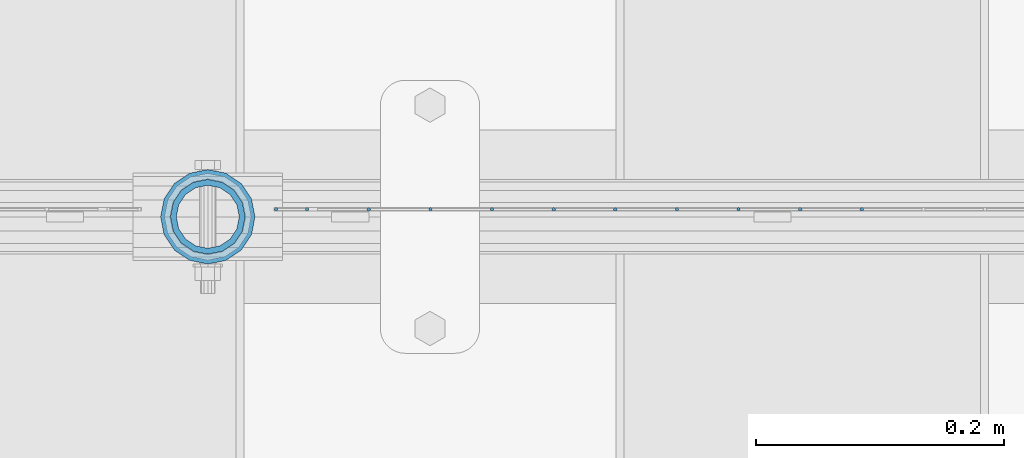
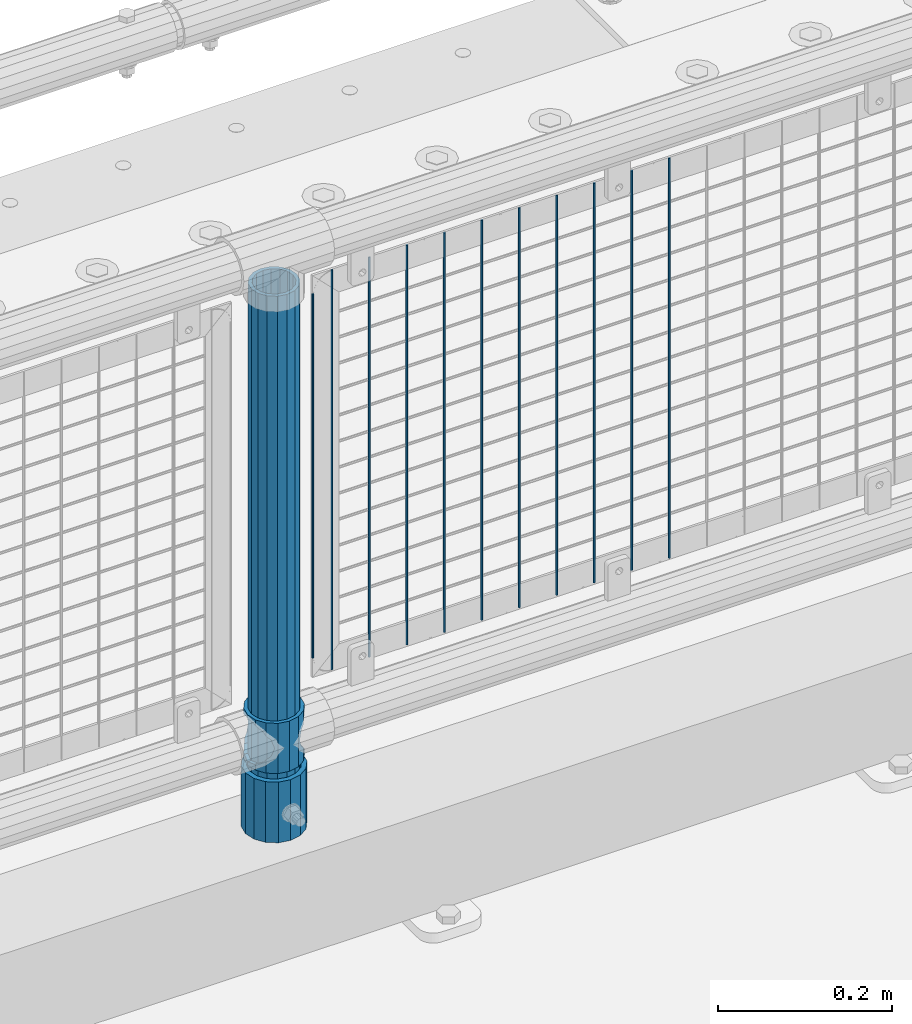
# One storey, part 92 of 257: 14 columns.
"""IFC2X3 building model written with IfcOpenShell, lengths in millimetres."""

import ifcopenshell
import ifcopenshell.guid

model = None  # the IFC model being written
_history = None  # IfcOwnerHistory: only IFC2X3 demands one
_inside = {}  # id of a spatial element -> (the spatial element, [elements in it])
_under = {}  # id of a project, library or spatial element -> (it, [spatial elements below it])
_declared = {}  # id of a project -> (the project, [libraries it declares])
_typed = {}  # id of a type object -> (the type object, [elements of that type])
_made_of = {}  # id of a material, layer set ... -> (it, [elements and type objects made of it])


def new_model(schema):
    """Start an empty IFC model of exactly this schema.

    Asked for "IFC4X3", IfcOpenShell would pick the latest addendum, in which some entities
    have other attributes; the version numbers below select the first issue.
    IFC2X3 requires an IfcOwnerHistory on every rooted entity: one is made here for all.
    """
    global model, _history
    if schema == "IFC4X3":
        model = ifcopenshell.file(schema_version=(4, 3, 0, 0))
    else:
        model = ifcopenshell.file(schema=schema)
    _inside.clear()
    _under.clear()
    _declared.clear()
    _typed.clear()
    _made_of.clear()
    _history = None
    if model.schema == "IFC2X3":
        org = make("IfcOrganization", Name="unknown")
        user = make(
            "IfcPersonAndOrganization",
            ThePerson=make("IfcPerson", FamilyName="unknown"),
            TheOrganization=org,
        )
        app = make(
            "IfcApplication",
            ApplicationDeveloper=org,
            Version="unknown",
            ApplicationFullName="unknown",
            ApplicationIdentifier="unknown",
        )
        _history = make(
            "IfcOwnerHistory",
            OwningUser=user,
            OwningApplication=app,
            ChangeAction="ADDED",
            CreationDate=0,
        )
    return model


def make(cls, **values):
    """One entity of the class cls with the attributes given. An attribute that is None is left unset."""
    return model.create_entity(
        cls, **{name: value for name, value in values.items() if value is not None}
    )


def rooted(cls, **values):
    """An entity with a GlobalId (a new one), such as an element, a storey or a relation."""
    return make(cls, GlobalId=ifcopenshell.guid.new(), OwnerHistory=_history, **values)


def si_unit(unit_type, name, prefix=None):
    """IfcSIUnit, for example si_unit("LENGTHUNIT", "METRE", prefix="MILLI")."""
    return make("IfcSIUnit", UnitType=unit_type, Prefix=prefix, Name=name)


def assignment(units):
    """IfcUnitAssignment: the units of a project."""
    return None if units is None else make("IfcUnitAssignment", Units=units)


def point(xyz):
    """IfcCartesianPoint."""
    return None if xyz is None else make("IfcCartesianPoint", Coordinates=xyz)


def direction(xyz):
    """IfcDirection."""
    return None if xyz is None else make("IfcDirection", DirectionRatios=xyz)


def frame(location, z_axis=None, x_axis=None):
    """IfcAxis2Placement3D, a coordinate frame: its origin and axes. An axis left out is left unset."""
    return make(
        "IfcAxis2Placement3D",
        Location=point(location),
        Axis=direction(z_axis),
        RefDirection=direction(x_axis),
    )


def origin_with_axes():
    """The frame at (0, 0, 0) with the z axis (0, 0, 1) and the x axis (1, 0, 0) written out."""
    return frame((0.0, 0.0, 0.0), z_axis=(0.0, 0.0, 1.0), x_axis=(1.0, 0.0, 0.0))


def place(relative_to, where):
    """IfcLocalPlacement: puts the frame where relative to a parent placement (None: the world)."""
    return make(
        "IfcLocalPlacement", PlacementRelTo=relative_to, RelativePlacement=where
    )


def context(
    kind, dimensions, precision=None, world=None, true_north=None, identifier=None
):
    """IfcGeometricRepresentationContext, for example the 3D "Model" context."""
    return make(
        "IfcGeometricRepresentationContext",
        ContextIdentifier=identifier,
        ContextType=kind,
        CoordinateSpaceDimension=dimensions,
        Precision=precision,
        WorldCoordinateSystem=world,
        TrueNorth=true_north,
    )


def subcontext(parent, identifier, kind, view, scale=None):
    """IfcGeometricRepresentationSubContext, for example "Body" below "Model"."""
    return make(
        "IfcGeometricRepresentationSubContext",
        ContextIdentifier=identifier,
        ContextType=kind,
        ParentContext=parent,
        TargetScale=scale,
        TargetView=view,
    )


def project(units=None, contexts=None):
    """IfcProject with its units and contexts."""
    return rooted(
        "IfcProject",
        Name="project",
        RepresentationContexts=contexts,
        UnitsInContext=assignment(units),
    )


def spatial(cls, under=None, at=None, **own):
    """A site, building, storey or space (cls), placed at a placement, below another one or the project."""
    s = rooted(cls, ObjectPlacement=at, **own)
    if under is not None:
        _under.setdefault(under.id(), (under, []))[1].append(s)
    return s


def faces_of(points, faces, orient=None, outer=None):
    """IfcFace entities. A face is a list of loops; a loop is a list of indices into points, from 0.

    orient and outer hold one flag for each loop. By default every Orientation is true, the
    first loop of a face is its IfcFaceOuterBound and the others are IfcFaceBound.
    """
    made = []
    for i, loops in enumerate(faces):
        bounds = []
        for j, loop in enumerate(loops):
            is_outer = j == 0 if outer is None else outer[i][j]
            bounds.append(
                make(
                    "IfcFaceOuterBound" if is_outer else "IfcFaceBound",
                    Bound=make("IfcPolyLoop", Polygon=[points[k] for k in loop]),
                    Orientation=True if orient is None else orient[i][j],
                )
            )
        made.append(make("IfcFace", Bounds=bounds))
    return made


def faceted_brep(points, faces, orient=None, outer=None, voids=None):
    """IfcFacetedBrep: a solid bounded by flat faces; with voids (closed shells), ...WithVoids."""
    shared = [point(p) for p in points]
    hull = make("IfcClosedShell", CfsFaces=faces_of(shared, faces, orient, outer))
    if voids is None:
        return make("IfcFacetedBrep", Outer=hull)
    return make(
        "IfcFacetedBrepWithVoids",
        Outer=hull,
        Voids=[
            make(cls, CfsFaces=faces_of(shared, fs, o, b)) for cls, fs, o, b in voids
        ],
    )


def shape(context_of_items, identifier, shape_type, items):
    """IfcShapeRepresentation: the items that make up one representation, for example the "Body"."""
    return make(
        "IfcShapeRepresentation",
        ContextOfItems=context_of_items,
        RepresentationIdentifier=identifier,
        RepresentationType=shape_type,
        Items=items,
    )


def material(Name=None, Category=None):
    """IfcMaterial."""
    return make("IfcMaterial", Name=Name, Category=Category)


def made_of(thing, what):
    """Note that an element or type object is made of a material, layer set ...; save() writes the relation."""
    if what is not None:
        _made_of.setdefault(what.id(), (what, []))[1].append(thing)
    return thing


def type_object(cls, material=None, **own):
    """A type object (cls), such as IfcWallType, which elements share."""
    return made_of(rooted(cls, **own), material)


def element(
    cls,
    number,
    at=None,
    inside=None,
    cuts=None,
    type_object=None,
    material=None,
    context=None,
    identifier="Body",
    shape_type=None,
    held_by="IfcProductDefinitionShape",
    body=None,
    shapes=None,
    **own,
):
    """One element of the class cls, such as IfcWall. Its Tag is "e" and its number.

    at: its placement. inside: the storey or other place that contains it. cuts: it is an
    opening in that element (IfcRelVoidsElement). A single representation is given by context,
    identifier, shape_type and body (its items); several are given by shapes. held_by: the class
    of the entity that holds the representations. save() writes the other relations.
    """
    e = rooted(cls, Tag="e%d" % number, ObjectPlacement=at, **own)
    if body is not None:
        shapes = [shape(context, identifier, shape_type, body)]
    if shapes is not None:
        e.Representation = make(held_by, Representations=shapes)
    if inside is not None:
        _inside.setdefault(inside.id(), (inside, []))[1].append(e)
    if cuts is not None:
        rooted(
            "IfcRelVoidsElement", RelatingBuildingElement=cuts, RelatedOpeningElement=e
        )
    if type_object is not None:
        _typed.setdefault(type_object.id(), (type_object, []))[1].append(e)
    return made_of(e, material)


def aggregate(whole, parts):
    """IfcRelAggregates: a whole, such as a stair, and the parts it consists of."""
    return rooted("IfcRelAggregates", RelatingObject=whole, RelatedObjects=parts)


def save(model, path):
    """Write the relations noted so far, then the file.

    IfcRelAggregates (storeys below a building ...), IfcRelContainedInSpatialStructure (elements
    in a storey), IfcRelDefinesByType, IfcRelAssociatesMaterial and IfcRelDeclares: one each for
    every whole, place, type object, material and project.
    """
    for whole, parts in _under.values():
        aggregate(whole, parts)
    for where, things in _inside.values():
        rooted(
            "IfcRelContainedInSpatialStructure",
            RelatedElements=things,
            RelatingStructure=where,
        )
    for kind, things in _typed.values():
        rooted("IfcRelDefinesByType", RelatedObjects=things, RelatingType=kind)
    for what, things in _made_of.values():
        rooted("IfcRelAssociatesMaterial", RelatedObjects=things, RelatingMaterial=what)
    for by, libraries in _declared.values():
        rooted("IfcRelDeclares", RelatingContext=by, RelatedDefinitions=libraries)
    model.write(path)


model = new_model("IFC2X3")

# Units and contexts
model_context = context("Model", 3, precision=1e-05, world=origin_with_axes())
body_context = subcontext(model_context, "Body", "Model", "MODEL_VIEW")
ifc_project = project(units=[si_unit("LENGTHUNIT", "METRE", prefix="MILLI"), si_unit("AREAUNIT", "SQUARE_METRE"), si_unit("VOLUMEUNIT", "CUBIC_METRE"), si_unit("MASSUNIT", "GRAM", prefix="KILO"), si_unit("TIMEUNIT", "SECOND"), si_unit("PLANEANGLEUNIT", "RADIAN"), si_unit("SOLIDANGLEUNIT", "STERADIAN"), si_unit("THERMODYNAMICTEMPERATUREUNIT", "DEGREE_CELSIUS"), si_unit("LUMINOUSINTENSITYUNIT", "LUMEN")], contexts=[model_context])

# Site, building, storey
site_placement = place(None, origin_with_axes())
site = spatial("IfcSite", under=ifc_project, at=site_placement, CompositionType="ELEMENT")
building_placement = place(site_placement, origin_with_axes())
building = spatial("IfcBuilding", under=site, at=building_placement, Name="Standard", CompositionType="ELEMENT")
storey_placement = place(building_placement, origin_with_axes())
storey = spatial("IfcBuildingStorey", under=building, at=storey_placement, Name="Undefined", CompositionType="ELEMENT", Elevation=0.0)

# Columns
ifc_material_1 = material()
column_type_1 = type_object("IfcColumnType", PredefinedType="NOTDEFINED")
column_1_placement = place(storey_placement, frame((55870.9999998042, 10664.5, 168.019999999998), z_axis=(0.0, 1.0, 0.0), x_axis=(0.0, 0.0, 1.0)))
element("IfcColumn", 1, at=column_1_placement, inside=storey, type_object=column_type_1, material=ifc_material_1, context=body_context, shape_type="Brep", body=[
    faceted_brep([(0.0, -31.75, 0.0), (0.0, -29.3331751572332, 12.1501989775916), (85.0, -29.3331751572332, 12.1501989775916), (85.0, -31.75, 0.0), (0.0, -22.4506403026753, 22.4506403026735), (85.0, -22.4506403026753, 22.4506403026735), (0.0, -12.1501989775934, 29.3331751572332), (85.0, -12.1501989775934, 29.3331751572332), (0.0, 0.0, 31.75), (85.0, 0.0, 31.75), (0.0, 12.1501989775934, 29.3331751572332), (85.0, 12.1501989775934, 29.3331751572332), (0.0, 22.4506403026753, 22.4506403026735), (85.0, 22.4506403026753, 22.4506403026735), (0.0, 29.3331751572332, 12.1501989775916), (85.0, 29.3331751572332, 12.1501989775916), (0.0, 31.75, 0.0), (85.0, 31.75, 0.0), (0.0, 29.3331751572332, -12.1501989775916), (85.0, 29.3331751572332, -12.1501989775916), (0.0, 22.4506403026753, -22.4506403026735), (85.0, 22.4506403026753, -22.4506403026735), (0.0, 12.1501989775934, -29.3331751572332), (85.0, 12.1501989775934, -29.3331751572332), (0.0, 0.0, -31.75), (85.0, 0.0, -31.75), (0.0, -12.1501989775934, -29.3331751572332), (85.0, -12.1501989775934, -29.3331751572332), (0.0, -22.4506403026753, -22.4506403026735), (85.0, -22.4506403026753, -22.4506403026735), (0.0, -29.3331751572332, -12.1501989775916), (85.0, -29.3331751572332, -12.1501989775916), (0.0, -38.0500000000029, 0.0), (0.0, -35.1536162120537, -14.561104601491), (85.0, -35.1536162120537, -14.561104601491), (85.0, -38.0500000000029, 0.0), (0.0, -26.9054130241493, -26.9054130241475), (85.0, -26.9054130241493, -26.9054130241475), (0.0, -14.5611046014892, -35.1536162120537), (85.0, -14.5611046014892, -35.1536162120537), (0.0, 0.0, -38.0499999999993), (85.0, 0.0, -38.0499999999993), (0.0, 14.5611046014892, -35.1536162120537), (85.0, 14.5611046014892, -35.1536162120537), (0.0, 26.9054130241493, -26.9054130241475), (85.0, 26.9054130241493, -26.9054130241475), (0.0, 35.1536162120537, -14.561104601491), (85.0, 35.1536162120537, -14.561104601491), (0.0, 38.0500000000029, 0.0), (85.0, 38.0500000000029, 0.0), (0.0, 35.1536162120537, 14.561104601491), (85.0, 35.1536162120537, 14.561104601491), (0.0, 26.9054130241493, 26.9054130241475), (85.0, 26.9054130241493, 26.9054130241475), (0.0, 14.5611046014892, 35.1536162120537), (85.0, 14.5611046014892, 35.1536162120537), (0.0, 0.0, 38.0499999999993), (85.0, 0.0, 38.0499999999993), (0.0, -14.5611046014892, 35.1536162120537), (85.0, -14.5611046014892, 35.1536162120537), (0.0, -26.9054130241493, 26.9054130241475), (85.0, -26.9054130241493, 26.9054130241475), (0.0, -35.1536162120537, 14.561104601491), (85.0, -35.1536162120537, 14.561104601491)], [[[0, 1, 2, 3]], [[1, 4, 5, 2]], [[4, 6, 7, 5]], [[6, 8, 9, 7]], [[8, 10, 11, 9]], [[10, 12, 13, 11]], [[12, 14, 15, 13]], [[14, 16, 17, 15]], [[16, 18, 19, 17]], [[18, 20, 21, 19]], [[20, 22, 23, 21]], [[22, 24, 25, 23]], [[24, 26, 27, 25]], [[26, 28, 29, 27]], [[28, 30, 31, 29]], [[30, 0, 3, 31]], [[32, 33, 34, 35]], [[33, 36, 37, 34]], [[36, 38, 39, 37]], [[38, 40, 41, 39]], [[40, 42, 43, 41]], [[42, 44, 45, 43]], [[44, 46, 47, 45]], [[46, 48, 49, 47]], [[48, 50, 51, 49]], [[50, 52, 53, 51]], [[52, 54, 55, 53]], [[54, 56, 57, 55]], [[56, 58, 59, 57]], [[58, 60, 61, 59]], [[60, 62, 63, 61]], [[62, 32, 35, 63]], [[37, 39, 41, 43, 45, 47, 49, 51, 53, 55, 57, 59, 61, 63, 35, 34], [5, 7, 9, 11, 13, 15, 17, 19, 21, 23, 25, 27, 29, 31, 3, 2]], [[62, 60, 58, 56, 54, 52, 50, 48, 46, 44, 42, 40, 38, 36, 33, 32], [30, 28, 26, 24, 22, 20, 18, 16, 14, 12, 10, 8, 6, 4, 1, 0]]]),
])
ifc_material_2 = material(Name="Misc_Undefined")
column_type_2 = type_object("IfcColumnType", PredefinedType="NOTDEFINED")
column_2_placement = place(storey_placement, frame((55871.0, 10664.5, 263.02), z_axis=(-1.0, 0.0, 0.0), x_axis=(0.0, 0.0, 1.0)))
element("IfcColumn", 2, at=column_2_placement, inside=storey, type_object=column_type_2, material=ifc_material_2, context=body_context, shape_type="Brep", body=[
    faceted_brep([(63.1897438117172, 11.6144421722802, -32.8397438117245), (63.1897438117172, 11.6144421722802, -28.0397438117143), (56.6106908090114, 21.4606908090118, -21.4606908090136), (56.6106908090114, 21.4606908090118, -27.1226768591077), (61.9623795176756, 13.4513226476338, -32.4743655677739), (46.7644421722801, 28.0397438117179, -11.6144421722784), (46.7644421722801, 28.0397438117179, -20.0882031229921), (51.5310424080039, 24.8548033587067, -24.8548033587067), (35.1500000000015, 30.35, 0.0), (35.1499999999996, 30.3500000000004, -16.6306603983758), (23.5355578277192, 28.0397438117179, -11.6144421722784), (23.5355578277192, 28.0397438117179, -20.0882031229921), (18.7689575919954, 24.8548033587067, -24.8548033587067), (13.6893091909879, 21.4606908090118, -21.4606908090136), (13.6893091909879, 21.4606908090118, -27.1226768591077), (8.3376204823237, 13.4513226476338, -32.4743655677739), (7.11025618828211, 11.6144421722802, -28.0397438117143), (7.11025618828211, 11.6144421722802, -32.8397438117245), (4.79999999999961, 0.0, -30.3499999999985), (4.79999999999961, 0.0, -35.1500000000015), (7.11025618828205, -11.6144421722802, -28.0397438117143), (7.11025618828205, -11.6144421722802, -32.8397438117245), (13.6893091909879, -21.4606908090118, -21.4606908090136), (13.6893091909879, -21.4606908090118, -27.1226768591077), (8.33762048232484, -13.4513226476338, -32.4743655677739), (23.5355578277191, -28.0397438117179, -11.6144421722784), (23.5355578277191, -28.0397438117179, -20.0882031229849), (18.7689575919987, -24.8548033587067, -24.8548033587067), (35.1500000000015, -30.35, 0.0), (35.1499999999996, -30.3500000000004, -16.6306603983685), (46.7644421722801, -28.0397438117179, -11.6144421722784), (46.7644421722801, -28.0397438117179, -20.0882031229849), (51.5310424080038, -24.8548033587067, -24.8548033587067), (56.6106908090114, -21.4606908090118, -21.4606908090136), (56.6106908090114, -21.4606908090118, -27.1226768591077), (61.9623795176756, -13.4513226476338, -32.4743655677739), (63.1897438117172, -11.6144421722802, -28.0397438117143), (63.1897438117172, -11.6144421722802, -32.8397438117245), (65.4999999999997, 0.0, -30.3499999999985), (65.4999999999997, 0.0, -35.1500000000015), (0.0, -28.0397438117179, -11.6144421722784), (0.0, -30.3500000000004, 0.0), (0.0, -21.4606908090118, -21.4606908090136), (0.0, -11.6144421722802, -28.0397438117143), (0.0, 0.0, -30.3499999999985), (0.0, 11.6144421722802, -28.0397438117143), (0.0, 21.4606908090118, -21.4606908090136), (0.0, 28.0397438117179, -11.6144421722784), (0.0, 30.3500000000004, 0.0), (0.0, 28.0397438117179, 11.6144421722784), (23.5355578277192, 28.0397438117179, 11.6144421722784), (0.0, 21.4606908090118, 21.4606908090136), (13.6893091909879, 21.4606908090118, 21.4606908090136), (0.0, 11.6144421722802, 28.0397438117143), (7.11025618828211, 11.6144421722802, 28.0397438117143), (0.0, 0.0, 30.3499999999985), (4.79999999999961, 0.0, 30.3499999999985), (0.0, -11.6144421722802, 28.0397438117143), (7.11025618828205, -11.6144421722802, 28.0397438117143), (0.0, -21.4606908090118, 21.4606908090136), (13.6893091909879, -21.4606908090118, 21.4606908090136), (0.0, -28.0397438117179, 11.6144421722784), (23.5355578277191, -28.0397438117179, 11.6144421722784), (0.0, -32.4743655677721, 13.4513226476338), (0.0, -35.1499999999996, 0.0), (70.2999999999993, -35.1499999999996, 0.0), (70.2999999999993, -32.4743655677721, 13.4513226476338), (0.0, 13.4513226476338, -32.4743655677739), (0.0, 24.8548033587067, -24.8548033587067), (0.0, 0.0, -35.1499999999996), (0.0, -13.4513226476338, -32.4743655677739), (0.0, -24.8548033587067, -24.8548033587067), (0.0, -24.8548033587067, 24.8548033587067), (0.0, -13.4513226476338, 32.4743655677739), (0.0, 0.0, 35.1499999999996), (0.0, 13.4513226476338, 32.4743655677739), (0.0, 24.8548033587067, 24.8548033587067), (0.0, 32.4743655677721, 13.4513226476338), (0.0, 35.1499999999996, 0.0), (0.0, 32.4743655677721, -13.4513226476338), (0.0, -32.4743655677721, -13.4513226476338), (70.2999999999993, 32.4743655677721, 13.4513226476338), (70.2999999999993, 35.1499999999996, 0.0), (70.2999999999993, 32.4743655677721, -13.4513226476338), (70.2999999999993, 24.8548033587067, -24.8548033587067), (70.2999999999993, 13.4513226476338, -32.4743655677739), (70.2999999999993, 0.0, -35.1500000000015), (70.2999999999993, -13.4513226476338, -32.4743655677739), (70.2999999999993, -24.8548033587067, -24.8548033587067), (70.2999999999993, -32.4743655677721, -13.4513226476338), (70.2999999999993, 28.0397438117179, 11.6144421722784), (70.2999999999993, 21.4606908090118, 21.4606908090136), (56.6106908090114, 21.4606908090118, 21.4606908090136), (46.7644421722801, 28.0397438117179, 11.6144421722784), (70.2999999999993, 11.6144421722802, 28.0397438117143), (63.1897438117172, 11.6144421722802, 28.0397438117143), (70.2999999999993, 0.0, 30.3499999999985), (65.4999999999997, 0.0, 30.3499999999985), (70.2999999999993, -11.6144421722802, 28.0397438117143), (63.1897438117172, -11.6144421722802, 28.0397438117143), (70.2999999999993, -21.4606908090118, 21.4606908090136), (56.6106908090114, -21.4606908090118, 21.4606908090136), (70.2999999999993, -28.0397438117179, 11.6144421722784), (46.7644421722801, -28.0397438117179, 11.6144421722784), (70.2999999999993, -11.6144421722802, -28.0397438117143), (70.2999999999993, 0.0, -30.3499999999985), (70.2999999999993, -21.4606908090118, -21.4606908090136), (70.2999999999993, -28.0397438117179, -11.6144421722784), (70.2999999999993, -30.3500000000004, 0.0), (70.2999999999993, 24.8548033587067, 24.8548033587067), (70.2999999999993, 13.4513226476338, 32.4743655677739), (70.2999999999993, 0.0, 35.1500000000015), (70.2999999999993, -13.4513226476338, 32.4743655677739), (70.2999999999993, -24.8548033587067, 24.8548033587067), (70.2999999999993, 30.3500000000004, 0.0), (70.2999999999993, 28.0397438117179, -11.6144421722784), (70.2999999999993, 21.4606908090118, -21.4606908090136), (70.2999999999993, 11.6144421722802, -28.0397438117143), (61.9623795176756, 13.4513226476338, 32.4743655677739), (51.5310424080039, 24.8548033587067, 24.8548033587067), (56.6106908090114, 21.4606908090118, 27.1226768591077), (65.4999999999997, 0.0, 35.1500000000015), (63.1897438117172, 11.6144421722802, 32.8397438117172), (63.1897438117172, -11.6144421722802, 32.8397438117172), (61.9623795176756, -13.4513226476338, 32.4743655677739), (56.6106908090114, -21.4606908090118, 27.1226768591077), (51.5310424080071, -24.8548033587067, 24.8548033587067), (18.7689575919987, -24.8548033587067, 24.8548033587067), (46.7644421722801, -28.0397438117179, 20.0882031229703), (35.1499999999996, -30.3500000000004, 16.6306603983539), (23.5355578277191, -28.0397438117179, 20.0882031229703), (8.3376204823237, -13.4513226476338, 32.4743655677739), (13.6893091909879, -21.4606908090118, 27.1226768591077), (4.79999999999961, 0.0, 35.1500000000015), (7.11025618828205, -11.6144421722802, 32.8397438117172), (7.11025618828211, 11.6144421722802, 32.8397438117172), (8.3376204823237, 13.4513226476338, 32.4743655677739), (13.6893091909879, 21.4606908090118, 27.1226768591077), (18.7689575919954, 24.8548033587067, 24.8548033587067), (23.5355578277192, 28.0397438117179, 20.0882031229849), (35.1499999999996, 30.3500000000004, 16.6306603983685), (46.7644421722801, 28.0397438117179, 20.0882031229849)], [[[0, 1, 2, 3, 4]], [[3, 2, 5, 6, 7]], [[6, 5, 8, 9]], [[9, 8, 10, 11]], [[12, 11, 10, 13, 14]], [[15, 14, 13, 16, 17]], [[17, 16, 18, 19]], [[19, 18, 20, 21]], [[21, 20, 22, 23, 24]], [[23, 22, 25, 26, 27]], [[26, 25, 28, 29]], [[29, 28, 30, 31]], [[32, 31, 30, 33, 34]], [[35, 34, 33, 36, 37]], [[37, 36, 38, 39]], [[39, 38, 1, 0]], [[40, 41, 28, 25]], [[42, 40, 25, 22]], [[43, 42, 22, 20]], [[44, 43, 20, 18]], [[45, 44, 18, 16]], [[46, 45, 16, 13]], [[47, 46, 13, 10]], [[48, 47, 10, 8]], [[49, 48, 8, 50]], [[51, 49, 50, 52]], [[53, 51, 52, 54]], [[55, 53, 54, 56]], [[57, 55, 56, 58]], [[59, 57, 58, 60]], [[61, 59, 60, 62]], [[41, 61, 62, 28]], [[63, 64, 65, 66]], [[67, 68, 12, 14, 15]], [[69, 67, 15, 17, 19]], [[24, 70, 69, 19, 21]], [[27, 71, 70, 24, 23]], [[63, 72, 73, 74, 75, 76, 77, 78, 79, 68, 67, 69, 70, 71, 80, 64], [40, 42, 43, 44, 45, 46, 47, 48, 49, 51, 53, 55, 57, 59, 61, 41]], [[78, 77, 81, 82]], [[79, 78, 82, 83]], [[9, 11, 12, 68, 79, 83, 84, 7, 6]], [[7, 84, 85, 4, 3]], [[4, 85, 86, 39, 0]], [[87, 88, 32, 34, 35]], [[86, 87, 35, 37, 39]], [[88, 89, 80, 71, 27, 26, 29, 31, 32]], [[64, 80, 89, 65]], [[90, 91, 92, 93]], [[91, 94, 95, 92]], [[94, 96, 97, 95]], [[96, 98, 99, 97]], [[98, 100, 101, 99]], [[100, 102, 103, 101]], [[104, 105, 38, 36]], [[106, 104, 36, 33]], [[107, 106, 33, 30]], [[108, 107, 30, 28]], [[102, 108, 28, 103]], [[88, 87, 86, 85, 84, 83, 82, 81, 109, 110, 111, 112, 113, 66, 65, 89], [100, 98, 96, 94, 91, 90, 114, 115, 116, 117, 105, 104, 106, 107, 108, 102]], [[118, 110, 109, 119, 120]], [[121, 111, 110, 118, 122]], [[112, 111, 121, 123, 124]], [[113, 112, 124, 125, 126]], [[127, 72, 63, 66, 113, 126, 128, 129, 130]], [[131, 73, 72, 127, 132]], [[133, 74, 73, 131, 134]], [[75, 74, 133, 135, 136]], [[76, 75, 136, 137, 138]], [[119, 109, 81, 77, 76, 138, 139, 140, 141]], [[92, 120, 119, 141, 93]], [[95, 122, 118, 120, 92]], [[97, 121, 122, 95]], [[99, 123, 121, 97]], [[101, 125, 124, 123, 99]], [[103, 128, 126, 125, 101]], [[28, 129, 128, 103]], [[62, 130, 129, 28]], [[60, 132, 127, 130, 62]], [[58, 134, 131, 132, 60]], [[56, 133, 134, 58]], [[54, 135, 133, 56]], [[52, 137, 136, 135, 54]], [[50, 139, 138, 137, 52]], [[8, 140, 139, 50]], [[93, 141, 140, 8]], [[114, 90, 93, 8]], [[115, 114, 8, 5]], [[116, 115, 5, 2]], [[117, 116, 2, 1]], [[105, 117, 1, 38]]]),
])
column_type_3 = type_object("IfcColumnType", PredefinedType="NOTDEFINED")
column_3_placement = place(storey_placement, frame((55870.9999998042, 10664.5, 168.019999999998), z_axis=(-1.0, 0.0, 0.0), x_axis=(0.0, 0.0, 1.0)))
element("IfcColumn", 3, at=column_3_placement, inside=storey, type_object=column_type_3, material=ifc_material_1, context=body_context, shape_type="Brep", body=[
    faceted_brep([(0.0, -25.3500000000004, 0.0), (0.0, -23.4203461491616, 9.70102501045767), (760.0, -23.4203461491616, 9.70102501045767), (760.0, -25.3500000000004, 0.0), (0.0, -17.9251569030785, 17.9251569030821), (760.0, -17.9251569030785, 17.9251569030821), (0.0, -9.70102501045585, 23.4203461491634), (760.0, -9.70102501045585, 23.4203461491634), (0.0, 0.0, 25.3499999999985), (760.0, 0.0, 25.3499999999985), (0.0, 9.70102501045585, 23.4203461491634), (760.0, 9.70102501045585, 23.4203461491634), (0.0, 17.9251569030785, 17.9251569030821), (760.0, 17.9251569030785, 17.9251569030821), (0.0, 23.4203461491616, 9.70102501045767), (760.0, 23.4203461491616, 9.70102501045767), (0.0, 25.3500000000004, 0.0), (760.0, 25.3500000000004, 0.0), (0.0, 23.4203461491616, -9.70102501045767), (760.0, 23.4203461491616, -9.70102501045767), (0.0, 17.9251569030785, -17.9251569030821), (760.0, 17.9251569030785, -17.9251569030821), (0.0, 9.70102501045585, -23.4203461491634), (760.0, 9.70102501045585, -23.4203461491634), (0.0, 0.0, -25.3499999999985), (760.0, 0.0, -25.3499999999985), (0.0, -9.70102501045585, -23.4203461491634), (760.0, -9.70102501045585, -23.4203461491634), (0.0, -17.9251569030785, -17.9251569030821), (760.0, -17.9251569030785, -17.9251569030821), (0.0, -23.4203461491616, -9.70102501045767), (760.0, -23.4203461491616, -9.70102501045767), (0.0, -30.1499999999996, 0.0), (0.0, -27.8549679052157, -11.5379054858058), (760.0, -27.8549679052157, -11.5379054858058), (760.0, -30.1499999999996, 0.0), (0.0, -21.3192694527752, -21.3192694527752), (760.0, -21.3192694527752, -21.3192694527752), (0.0, -11.5379054858076, -27.8549679052157), (760.0, -11.5379054858076, -27.8549679052157), (0.0, 0.0, -30.1500000000015), (760.0, 0.0, -30.1500000000015), (0.0, 11.5379054858076, -27.8549679052157), (760.0, 11.5379054858076, -27.8549679052157), (0.0, 21.3192694527752, -21.3192694527752), (760.0, 21.3192694527752, -21.3192694527752), (0.0, 27.8549679052157, -11.5379054858058), (760.0, 27.8549679052157, -11.5379054858058), (0.0, 30.1499999999996, 0.0), (760.0, 30.1499999999996, 0.0), (0.0, 27.8549679052157, 11.5379054858058), (760.0, 27.8549679052157, 11.5379054858058), (0.0, 21.3192694527752, 21.3192694527752), (760.0, 21.3192694527752, 21.3192694527752), (0.0, 11.5379054858076, 27.8549679052157), (760.0, 11.5379054858076, 27.8549679052157), (0.0, 0.0, 30.1500000000015), (760.0, 0.0, 30.1500000000015), (0.0, -11.5379054858076, 27.8549679052157), (760.0, -11.5379054858076, 27.8549679052157), (0.0, -21.3192694527752, 21.3192694527752), (760.0, -21.3192694527752, 21.3192694527752), (0.0, -27.8549679052157, 11.5379054858058), (760.0, -27.8549679052157, 11.5379054858058)], [[[0, 1, 2, 3]], [[1, 4, 5, 2]], [[4, 6, 7, 5]], [[6, 8, 9, 7]], [[8, 10, 11, 9]], [[10, 12, 13, 11]], [[12, 14, 15, 13]], [[14, 16, 17, 15]], [[16, 18, 19, 17]], [[18, 20, 21, 19]], [[20, 22, 23, 21]], [[22, 24, 25, 23]], [[24, 26, 27, 25]], [[26, 28, 29, 27]], [[28, 30, 31, 29]], [[30, 0, 3, 31]], [[32, 33, 34, 35]], [[33, 36, 37, 34]], [[36, 38, 39, 37]], [[38, 40, 41, 39]], [[40, 42, 43, 41]], [[42, 44, 45, 43]], [[44, 46, 47, 45]], [[46, 48, 49, 47]], [[48, 50, 51, 49]], [[50, 52, 53, 51]], [[52, 54, 55, 53]], [[54, 56, 57, 55]], [[56, 58, 59, 57]], [[58, 60, 61, 59]], [[60, 62, 63, 61]], [[62, 32, 35, 63]], [[37, 39, 41, 43, 45, 47, 49, 51, 53, 55, 57, 59, 61, 63, 35, 34], [5, 7, 9, 11, 13, 15, 17, 19, 21, 23, 25, 27, 29, 31, 3, 2]], [[62, 60, 58, 56, 54, 52, 50, 48, 46, 44, 42, 40, 38, 36, 33, 32], [30, 28, 26, 24, 22, 20, 18, 16, 14, 12, 10, 8, 6, 4, 1, 0]]]),
])
column_type_4 = type_object("IfcColumnType", Name="D3", PredefinedType="NOTDEFINED")
for number, where, z_axis, x_axis in (
    (4, (56397.895, 10670.5, 353.020000000006), (-1.0, 0.0, 0.0), (0.0, 0.0, 1.0)),
    (5, (56348.24, 10670.5, 353.020000000006), (-1.0, 0.0, 0.0), (0.0, 0.0, 1.0)),
    (6, (56298.585, 10670.5, 353.020000000006), (-1.0, 0.0, 0.0), (0.0, 0.0, 1.0)),
    (7, (56248.93, 10670.5, 353.020000000006), (-1.0, 0.0, 0.0), (0.0, 0.0, 1.0)),
    (8, (56199.275, 10670.5, 353.020000000006), (-1.0, 0.0, 0.0), (0.0, 0.0, 1.0)),
    (9, (56149.62, 10670.5, 353.020000000006), (-1.0, 0.0, 0.0), (0.0, 0.0, 1.0)),
    (10, (56099.965, 10670.5, 353.020000000006), (-1.0, 0.0, 0.0), (0.0, 0.0, 1.0)),
    (11, (56050.3103448276, 10670.5, 353.020000000006), (-1.0, 0.0, 0.0), (0.0, 0.0, 1.0)),
    (12, (56000.6551724138, 10670.5, 353.020000000006), (-0.999999999962839, 0.0, 8.62099999968473e-06), (8.62099999949798e-06, 0.0, 0.999999999962839)),
):
    element("IfcColumn", number, at=place(storey_placement, frame(where, z_axis=z_axis, x_axis=x_axis)), inside=storey, type_object=column_type_4, material=ifc_material_2, ObjectType="D3", context=body_context, shape_type="Brep", body=[
        faceted_brep([(0.0, -1.5, -5.6843418860808e-14), (0.0, -0.750000000001819, -1.29903810567669), (560.0, -0.75, -1.29903810567339), (560.0, -1.5, 0.0), (7.27595761418343e-12, 0.749999999998181, -1.29903810567669), (560.0, 0.75, -1.29903810567339), (0.0, 1.5, -5.6843418860808e-14), (560.0, 1.5, 0.0), (7.27595761418343e-12, 0.749999999998181, 1.29903810567669), (560.0, 0.75, 1.29903810567339), (0.0, -0.750000000001819, 1.29903810567669), (560.0, -0.75, 1.29903810567339)], [[[0, 1, 2, 3]], [[1, 4, 5, 2]], [[4, 6, 7, 5]], [[6, 8, 9, 7]], [[8, 10, 11, 9]], [[10, 0, 3, 11]], [[5, 7, 9, 11, 3, 2]], [[10, 8, 6, 4, 1, 0]]]),
    ])
column_4_placement = place(storey_placement, frame((55926.0, 10670.5, 378.020000000006), z_axis=(-1.0, 0.0, 0.0), x_axis=(0.0, 0.0, 1.0)))
element("IfcColumn", 13, at=column_4_placement, inside=storey, type_object=column_type_4, material=ifc_material_2, ObjectType="D3", context=body_context, shape_type="Brep", body=[
    faceted_brep([(0.0, -1.5, -5.6843418860808e-14), (0.0, -0.750000000001819, -1.29903810567669), (510.0, -0.75, -1.29903810567339), (510.0, -1.5, 0.0), (7.27595761418343e-12, 0.749999999998181, -1.29903810567669), (510.0, 0.75, -1.29903810567339), (0.0, 1.5, -5.6843418860808e-14), (510.0, 1.5, 0.0), (7.27595761418343e-12, 0.749999999998181, 1.29903810567669), (510.0, 0.75, 1.29903810567339), (0.0, -0.750000000001819, 1.29903810567669), (510.0, -0.75, 1.29903810567339)], [[[0, 1, 2, 3]], [[1, 4, 5, 2]], [[4, 6, 7, 5]], [[6, 8, 9, 7]], [[8, 10, 11, 9]], [[10, 0, 3, 11]], [[5, 7, 9, 11, 3, 2]], [[10, 8, 6, 4, 1, 0]]]),
])
column_5_placement = place(storey_placement, frame((55951.0, 10670.5, 353.020000000006), z_axis=(-1.0, 0.0, 0.0), x_axis=(0.0, 0.0, 1.0)))
element("IfcColumn", 14, at=column_5_placement, inside=storey, type_object=column_type_4, material=ifc_material_2, ObjectType="D3", context=body_context, shape_type="Brep", body=[
    faceted_brep([(0.0, -1.5, -5.6843418860808e-14), (0.0, -0.750000000001819, -1.29903810567669), (560.0, -0.75, -1.29903810567339), (560.0, -1.5, 0.0), (7.27595761418343e-12, 0.749999999998181, -1.29903810567669), (560.0, 0.75, -1.29903810567339), (0.0, 1.5, -5.6843418860808e-14), (560.0, 1.5, 0.0), (7.27595761418343e-12, 0.749999999998181, 1.29903810567669), (560.0, 0.75, 1.29903810567339), (0.0, -0.750000000001819, 1.29903810567669), (560.0, -0.75, 1.29903810567339)], [[[0, 1, 2, 3]], [[1, 4, 5, 2]], [[4, 6, 7, 5]], [[6, 8, 9, 7]], [[8, 10, 11, 9]], [[10, 0, 3, 11]], [[5, 7, 9, 11, 3, 2]], [[10, 8, 6, 4, 1, 0]]]),
])

save(model, "model.ifc")
